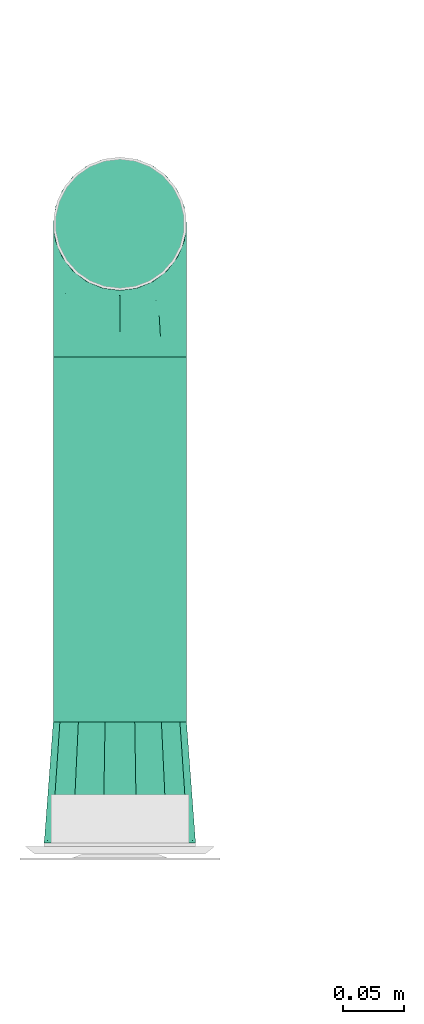
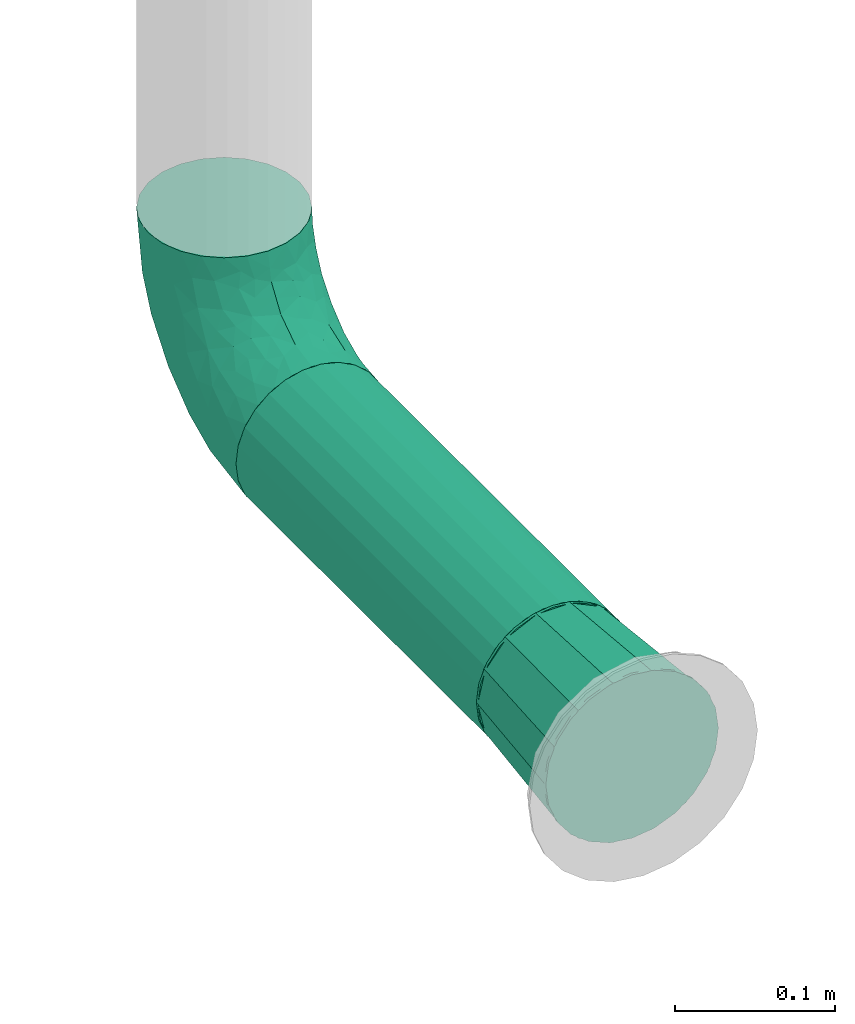
# One storey, part 46 of 123: 2 flow fittings, 1 flow segment.
"""IFC2X3 building model written with IfcOpenShell, lengths in millimetres."""

from ifc_helpers import new_model, entity, si_unit, converted_unit, derived_unit, direction, frame, origin_with_axes, origin_2d_with_axis, place, context, subcontext, project, spatial, hollow_circle, extrude, open_shell, surface_model, source, transform, mapped, material, layer, layer_set, layer_usage, type_object, element, save


model = new_model("IFC2X3")

# Units and contexts
model_context = context("Model", 3, precision=1e-05, world=origin_with_axes(), true_north=direction((0.0, 1.0)))
body_context = subcontext(model_context, "Body", "Model", "MODEL_VIEW")
ifc_project = project(units=[si_unit("AREAUNIT", "SQUARE_METRE"), si_unit("VOLUMEUNIT", "CUBIC_METRE", prefix="DECI"), si_unit("TIMEUNIT", "SECOND"), si_unit("THERMODYNAMICTEMPERATUREUNIT", "DEGREE_CELSIUS"), si_unit("PRESSUREUNIT", "PASCAL"), si_unit("MASSUNIT", "GRAM", prefix="KILO"), si_unit("LENGTHUNIT", "METRE", prefix="MILLI"), si_unit("POWERUNIT", "WATT"), si_unit("ELECTRICCURRENTUNIT", "AMPERE"), si_unit("ELECTRICVOLTAGEUNIT", "VOLT"), derived_unit("VOLUMETRICFLOWRATEUNIT", [(si_unit("VOLUMEUNIT", "CUBIC_METRE", prefix="DECI"), 1), (si_unit("TIMEUNIT", "SECOND"), -1)]), derived_unit("LINEARVELOCITYUNIT", [(si_unit("LENGTHUNIT", "METRE"), 1), (si_unit("TIMEUNIT", "SECOND"), -1)]), derived_unit("MASSDENSITYUNIT", [(si_unit("MASSUNIT", "GRAM", prefix="KILO"), 1), (si_unit("VOLUMEUNIT", "CUBIC_METRE"), -1)]), converted_unit("PLANEANGLEUNIT", "DEGREE", entity("IfcRatioMeasure", 0.01745), si_unit("PLANEANGLEUNIT", "RADIAN"), dimensions=[0, 0, 0, 0, 0, 0, 0])], contexts=[model_context])

# Site, building, storey
site_placement = place(None, origin_with_axes())
site = spatial("IfcSite", under=ifc_project, at=site_placement, CompositionType="ELEMENT")
building_placement = place(site_placement, origin_with_axes())
building = spatial("IfcBuilding", under=site, at=building_placement, Name="mc-building", CompositionType="ELEMENT")
storey_placement = place(building_placement, origin_with_axes())
storey = spatial("IfcBuildingStorey", under=building, at=storey_placement, Name="1. Korrus", CompositionType="ELEMENT", Elevation=0.0)

# Flow fitting
duct_fitting_type_1 = type_object("IfcDuctFittingType", PredefinedType="TRANSITION")
shared_shape_1 = source(origin_with_axes(), body_context, "Body", "SurfaceModel", [
    surface_model("IfcShellBasedSurfaceModel", [(0.0, 16.17619, 60.37037), (0.0, -44.19417, 44.19417), (0.0, 0.0, 62.5), (0.0, 44.19417, 44.19417), (0.0, 31.25, 54.12659), (0.0, 54.12659, 31.25), (0.0, 60.37037, 16.17619), (0.0, -44.19417, -44.19417), (0.0, -16.17619, 60.37037), (0.0, -31.25, 54.12659), (0.0, -60.37037, 16.17619), (0.0, -54.12659, 31.25), (0.0, -62.5, 0.0), (0.0, 62.5, 0.0), (0.0, 60.37037, -16.17619), (0.0, 16.17619, -60.37037), (0.0, 54.12659, -31.25), (0.0, 44.19417, -44.19417), (0.0, 31.25, -54.12659), (0.0, -60.37037, -16.17619), (0.0, -54.12659, -31.25), (0.0, -31.25, -54.12659), (0.0, 0.0, -62.5), (0.0, -16.17619, -60.37037), (100.0, -55.0, 0.0), (100.0, -34.29194, 43.00073), (100.0, -49.55329, 23.86361), (100.0, 34.29194, -43.00073), (100.0, 49.55329, -23.86361), (100.0, 12.23865, -53.62104), (100.0, -34.29194, -43.00073), (100.0, -12.23865, -53.62104), (100.0, 27.5, -47.63139), (100.0, 0.0, -55.0), (100.0, 14.23505, -53.12592), (100.0, 38.89087, -38.89087), (100.0, -27.5, -47.63139), (100.0, 47.63139, -27.5), (100.0, 53.12592, -14.23505), (100.0, 55.0, 0.0), (100.0, -14.23505, -53.12592), (100.0, -47.63139, -27.5), (100.0, -38.89087, -38.89087), (100.0, -53.12592, -14.23505), (100.0, 53.12592, 14.23505), (100.0, 47.63139, 27.5), (100.0, 27.5, 47.63139), (100.0, 38.89087, 38.89087), (100.0, 14.23505, 53.12592), (100.0, 0.0, 55.0), (100.0, -47.63139, 27.5), (100.0, -53.12592, 14.23505), (100.0, -27.5, 47.63139), (100.0, -38.89087, 38.89087), (100.0, -14.23505, 53.12592), (98.0, 0.0, 55.0), (98.0, 14.23505, 53.12592), (98.0, 27.5, 47.63139), (98.0, 38.89087, 38.89087), (98.0, 47.63139, 27.5), (98.0, -47.63139, 27.5), (98.0, 53.12592, -14.23505), (98.0, -27.5, 47.63139), (98.0, -14.23505, 53.12592), (98.0, -38.89087, 38.89087), (98.0, -55.0, 0.0), (98.0, -53.12592, 14.23505), (98.0, 53.12592, 14.23505), (98.0, 47.63139, -27.5), (98.0, -27.5, -47.63139), (98.0, 0.0, -55.0), (98.0, 38.89087, -38.89087), (98.0, 27.5, -47.63139), (98.0, 14.23505, -53.12592), (98.0, -47.63139, -27.5), (98.0, -38.89087, -38.89087), (98.0, -53.12592, -14.23505), (98.0, -14.23505, -53.12592), (98.0, 55.0, 0.0), (100.0, 12.23865, 53.62104), (100.0, -12.23865, 53.62104), (100.0, 49.55329, 23.86361), (100.0, 34.29194, 43.00073), (100.0, -49.55329, -23.86361), (0.0, -56.31055, -27.11773), (0.0, 13.90756, 60.93299), (0.0, 38.96811, 48.86447), (0.0, -13.90756, 60.93299), (0.0, -56.31055, 27.11773), (0.0, -38.96811, 48.86447), (0.0, 56.31055, 27.11773), (0.0, -38.96811, -48.86447), (0.0, 56.31055, -27.11773), (0.0, 38.96811, -48.86447), (0.0, -13.90756, -60.93299), (0.0, 13.90756, -60.93299), (0.0, 59.28804, -14.07253), (100.0, 52.27664, -11.9318), (0.0, 47.63933, -37.9911), (100.0, 41.92261, -33.43217), (0.0, 26.43783, -54.89873), (100.0, 0.0, -53.62104), (0.0, 0.0, -60.93299), (0.0, -26.43783, -54.89873), (100.0, -23.2653, -48.31088), (100.0, 23.2653, -48.31088), (0.0, -59.28804, -14.07253), (100.0, -52.27664, -11.9318), (0.0, -47.63933, -37.9911), (100.0, -41.92261, -33.43217), (0.0, -59.28804, 14.07253), (100.0, -52.27664, 11.9318), (0.0, -47.63933, 37.9911), (100.0, -41.92261, 33.43217), (0.0, -26.43783, 54.89873), (100.0, 0.0, 53.62104), (0.0, 0.0, 60.93299), (0.0, 26.43783, 54.89873), (100.0, 23.2653, 48.31088), (100.0, -23.2653, 48.31088), (0.0, 59.28804, 14.07253), (100.0, 52.27664, 11.9318), (0.0, 47.63933, 37.9911), (100.0, 41.92261, 33.43217), (2.0, 16.17619, -60.37037), (2.0, 31.25, -54.12659), (2.0, 44.19417, -44.19417), (2.0, 54.12659, -31.25), (2.0, 60.37037, -16.17619), (2.0, -44.19417, -44.19417), (2.0, 62.5, 0.0), (2.0, 0.0, -62.5), (2.0, -31.25, -54.12659), (2.0, -16.17619, -60.37037), (2.0, -60.37037, -16.17619), (2.0, -54.12659, -31.25), (2.0, -62.5, 0.0), (2.0, -44.19417, 44.19417), (2.0, 0.0, 62.5), (2.0, 60.37037, 16.17619), (2.0, 54.12659, 31.25), (2.0, 16.17619, 60.37037), (2.0, 44.19417, 44.19417), (2.0, 31.25, 54.12659), (2.0, -60.37037, 16.17619), (2.0, -54.12659, 31.25), (2.0, -16.17619, 60.37037), (2.0, -31.25, 54.12659)], [open_shell([[[0, 1, 2]], [[3, 0, 4]], [[5, 6, 0]], [[5, 0, 3]], [[0, 7, 1]], [[8, 1, 9]], [[8, 2, 1]], [[1, 10, 11]], [[10, 1, 12]], [[1, 7, 12]], [[0, 6, 13]], [[14, 7, 13]], [[15, 14, 16]], [[17, 18, 15]], [[17, 15, 16]], [[7, 14, 15]], [[19, 7, 20]], [[12, 7, 19]], [[21, 22, 23]], [[22, 21, 7]], [[15, 22, 7]], [[7, 0, 13]], [[24, 25, 26]], [[27, 28, 29]], [[29, 28, 24]], [[30, 31, 29]], [[32, 33, 34]], [[35, 36, 32]], [[36, 37, 38]], [[35, 37, 36]], [[39, 36, 38]], [[33, 36, 40]], [[33, 32, 36]], [[36, 41, 42]], [[36, 39, 41]], [[24, 43, 41]], [[41, 39, 44]], [[45, 24, 44]], [[46, 45, 47]], [[46, 48, 49]], [[45, 46, 24]], [[49, 50, 46]], [[24, 50, 51]], [[24, 46, 50]], [[49, 52, 53]], [[53, 50, 49]], [[52, 49, 54]], [[44, 24, 41]], [[55, 56, 57]], [[55, 57, 58]], [[55, 59, 60]], [[59, 55, 58]], [[61, 60, 59]], [[55, 62, 63]], [[55, 64, 62]], [[60, 65, 66]], [[64, 55, 60]], [[60, 61, 65]], [[61, 59, 67]], [[61, 68, 65]], [[68, 69, 65]], [[70, 71, 72]], [[68, 71, 70]], [[72, 73, 70]], [[74, 69, 75]], [[76, 65, 74]], [[69, 70, 77]], [[74, 65, 69]], [[70, 69, 68]], [[78, 61, 67]], [[76, 43, 65]], [[74, 41, 76]], [[36, 75, 69]], [[74, 75, 42]], [[40, 69, 77]], [[76, 41, 43]], [[43, 24, 65]], [[40, 36, 69]], [[42, 75, 36]], [[42, 41, 74]], [[33, 40, 77]], [[77, 70, 33]], [[73, 34, 70]], [[72, 32, 73]], [[37, 71, 68]], [[72, 71, 35]], [[38, 68, 61]], [[72, 35, 32]], [[32, 34, 73]], [[39, 38, 61]], [[37, 68, 38]], [[37, 35, 71]], [[78, 39, 61]], [[70, 34, 33]], [[67, 44, 78]], [[59, 45, 67]], [[46, 58, 57]], [[59, 58, 47]], [[48, 57, 56]], [[67, 45, 44]], [[44, 39, 78]], [[48, 46, 57]], [[47, 58, 46]], [[47, 45, 59]], [[49, 48, 56]], [[56, 55, 49]], [[63, 54, 55]], [[62, 52, 63]], [[50, 64, 60]], [[62, 64, 53]], [[51, 60, 66]], [[62, 53, 52]], [[52, 54, 63]], [[24, 51, 66]], [[50, 60, 51]], [[50, 53, 64]], [[65, 24, 66]], [[55, 54, 49]], [[24, 79, 80]], [[25, 24, 80]], [[81, 82, 24]], [[24, 39, 81]], [[79, 24, 82]], [[24, 83, 30]], [[24, 30, 29]], [[24, 28, 39]], [[84, 85, 86]], [[84, 87, 85]], [[88, 89, 84]], [[84, 12, 88]], [[87, 84, 89]], [[13, 86, 90]], [[91, 13, 92]], [[91, 92, 93]], [[84, 13, 91]], [[94, 91, 93]], [[95, 94, 93]], [[13, 84, 86]], [[28, 96, 97]], [[98, 28, 99]], [[27, 100, 93]], [[101, 94, 102]], [[103, 31, 104]], [[28, 98, 92]], [[102, 95, 29]], [[13, 97, 96]], [[105, 29, 95]], [[99, 93, 98]], [[105, 95, 100]], [[99, 27, 93]], [[94, 101, 31]], [[31, 103, 94]], [[106, 83, 107]], [[83, 84, 108]], [[30, 109, 91]], [[12, 106, 107]], [[12, 107, 24]], [[97, 13, 39]], [[104, 91, 103]], [[28, 92, 96]], [[83, 106, 84]], [[108, 109, 83]], [[100, 27, 105]], [[91, 109, 108]], [[102, 29, 101]], [[104, 30, 91]], [[26, 110, 111]], [[112, 26, 113]], [[25, 114, 89]], [[115, 85, 116]], [[117, 79, 118]], [[26, 112, 88]], [[116, 87, 80]], [[12, 111, 110]], [[119, 80, 87]], [[113, 89, 112]], [[119, 87, 114]], [[113, 25, 89]], [[85, 115, 79]], [[79, 117, 85]], [[120, 81, 121]], [[81, 90, 122]], [[82, 123, 86]], [[13, 120, 121]], [[13, 121, 39]], [[111, 12, 24]], [[118, 86, 117]], [[26, 88, 110]], [[81, 120, 90]], [[122, 123, 81]], [[114, 25, 119]], [[86, 123, 122]], [[116, 80, 115]], [[118, 82, 86]], [[124, 125, 126]], [[124, 126, 127]], [[124, 128, 129]], [[128, 124, 127]], [[129, 128, 130]], [[131, 132, 133]], [[132, 131, 129]], [[129, 134, 135]], [[129, 131, 124]], [[129, 136, 134]], [[129, 130, 137]], [[138, 139, 140]], [[141, 140, 142]], [[141, 138, 140]], [[141, 142, 143]], [[139, 138, 137]], [[144, 137, 145]], [[137, 144, 136]], [[137, 146, 147]], [[136, 129, 137]], [[138, 146, 137]], [[137, 130, 139]], [[19, 134, 12]], [[20, 135, 19]], [[132, 7, 21]], [[20, 7, 129]], [[133, 21, 23]], [[19, 135, 134]], [[134, 136, 12]], [[133, 132, 21]], [[129, 7, 132]], [[129, 135, 20]], [[131, 133, 23]], [[23, 22, 131]], [[15, 124, 22]], [[18, 125, 15]], [[127, 17, 16]], [[18, 17, 126]], [[128, 16, 14]], [[18, 126, 125]], [[125, 124, 15]], [[130, 128, 14]], [[127, 16, 128]], [[127, 126, 17]], [[13, 130, 14]], [[22, 124, 131]], [[6, 139, 13]], [[5, 140, 6]], [[143, 3, 4]], [[5, 3, 142]], [[141, 4, 0]], [[6, 140, 139]], [[139, 130, 13]], [[141, 143, 4]], [[142, 3, 143]], [[142, 140, 5]], [[138, 141, 0]], [[0, 2, 138]], [[8, 146, 2]], [[9, 147, 8]], [[145, 1, 11]], [[9, 1, 137]], [[144, 11, 10]], [[9, 137, 147]], [[147, 146, 8]], [[136, 144, 10]], [[145, 11, 144]], [[145, 137, 1]], [[12, 136, 10]], [[2, 146, 138]]])]),
])
flow_fitting_1_placement = place(storey_placement, frame((2232.32005, 7578.1, 2480.0), z_axis=(0.0, 0.0, 1.0), x_axis=(0.0, 1.0, 0.0)))
element("IfcFlowFitting", 1, at=flow_fitting_1_placement, inside=storey, type_object=duct_fitting_type_1, context=body_context, shape_type="MappedRepresentation", body=[
    mapped(shared_shape_1, transform((0.0, 0.0, 0.0), scale=1.0)),
])

# Flow segment
ifc_material = material(Name="FZ1")
ifc_layer = layer(ifc_material, 0.0)
ifc_layer_set = layer_set([ifc_layer], Name="FZ1")
ifc_layer_usage = layer_usage(ifc_layer_set, "AXIS1", "POSITIVE", 0.0)
duct_segment_type = type_object("IfcDuctSegmentType", PredefinedType="RIGIDSEGMENT")
shared_shape_2 = source(origin_with_axes(), body_context, "Body", "SweptSolid", [
    extrude(hollow_circle(Radius=55.0, WallThickness=2.0, at=origin_2d_with_axis()), frame((0.0, 0.0, 0.0), z_axis=(1.0, 0.0, 0.0), x_axis=(0.0, 1.0, 0.0)), (0.0, 0.0, 1.0), 301.3),
])
flow_segment_placement = place(storey_placement, frame((2232.32005, 7678.1, 2480.0), z_axis=(0.0, 0.0, 1.0), x_axis=(0.0, 1.0, 0.0)))
element("IfcFlowSegment", 2, at=flow_segment_placement, inside=storey, type_object=duct_segment_type, material=ifc_layer_usage, context=body_context, shape_type="MappedRepresentation", body=[
    mapped(shared_shape_2, transform((0.0, 0.0, 0.0), scale=1.0)),
])

# Flow fitting
duct_fitting_type_2 = type_object("IfcDuctFittingType", Name="BU", PredefinedType="BEND")
shared_shape_3 = source(origin_with_axes(), body_context, "Body", "SurfaceModel", [
    surface_model("IfcShellBasedSurfaceModel", [(-110.0, 0.0, -55.0), (-110.0, -14.23505, -53.12592), (-110.0, 14.23505, -53.12592), (-110.0, 53.12592, 14.23505), (-110.0, 27.5, -47.63139), (-110.0, 38.89087, -38.89087), (-110.0, -55.0, 0.0), (-110.0, -53.12592, 14.23505), (-110.0, -38.89087, -38.89087), (-110.0, -27.5, -47.63139), (-110.0, -53.12592, -14.23505), (-110.0, -47.63139, -27.5), (-110.0, -14.23505, 53.12592), (-110.0, 14.23505, 53.12592), (-110.0, 27.5, 47.63139), (-110.0, -47.63139, 27.5), (-110.0, -38.89087, 38.89087), (-110.0, -27.5, 47.63139), (-110.0, 0.0, 55.0), (-110.0, 55.0, 0.0), (-110.0, 53.12592, -14.23505), (-110.0, 47.63139, -27.5), (-110.0, 47.63139, 27.5), (-110.0, 38.89087, 38.89087), (-14.23505, 110.0, -53.12592), (-55.0, 110.0, 0.0), (0.0, 110.0, -55.0), (-27.5, 110.0, -47.63139), (-38.89087, 110.0, -38.89087), (-47.63139, 110.0, -27.5), (38.89087, 110.0, -38.89087), (53.12592, 110.0, 14.23505), (27.5, 110.0, -47.63139), (14.23505, 110.0, -53.12592), (47.63139, 110.0, -27.5), (53.12592, 110.0, -14.23505), (55.0, 110.0, 0.0), (-53.12592, 110.0, -14.23505), (-53.12592, 110.0, 14.23505), (-47.63139, 110.0, 27.5), (-38.89087, 110.0, 38.89087), (-27.5, 110.0, 47.63139), (0.0, 110.0, 55.0), (-14.23505, 110.0, 53.12592), (38.89087, 110.0, 38.89087), (47.63139, 110.0, 27.5), (27.5, 110.0, 47.63139), (14.23505, 110.0, 53.12592), (-64.21732, 48.68956, 43.63444), (-76.6405, 38.18013, 45.55988), (-60.44912, 32.56953, 51.94617), (-76.00813, 5.38378, 55.0), (-90.15553, 11.94394, 54.09138), (-78.5998, 26.77405, 50.81338), (-70.18771, 18.55163, 54.03432), (-75.55424, 54.2118, 32.41257), (-93.27622, 45.77614, 33.48188), (-96.12334, 22.13664, 50.81337), (-21.00813, 45.34362, 55.0), (-18.36258, 70.48427, 54.04484), (-32.04182, 59.64019, 52.24446), (-63.88653, 74.77858, 17.99134), (-74.66383, 63.08407, 19.92123), (-63.60674, 66.07878, 29.97482), (-99.597, 52.72185, 18.52927), (-93.11138, 56.59448, 10.50359), (-98.21577, 57.34403, 0.0), (-53.42855, 92.60092, 21.04759), (-88.54852, 54.8376, 21.04759), (-11.86161, 90.23965, 54.10313), (-5.38378, 76.00813, 55.0), (-57.34403, 98.21577, 0.0), (-56.64619, 93.12774, 10.22088), (-45.34362, 21.00813, 55.0), (-44.60838, 44.60838, 52.13415), (-92.68484, 35.46673, 43.63443), (-22.25266, 95.40765, 50.81337), (-35.97783, 90.61597, 43.63443), (-43.70931, 69.58671, 44.47149), (-27.23711, 77.39884, 50.81337), (-57.2828, 79.3123, 24.9774), (-58.67786, 84.31125, 16.04456), (-82.93277, 60.36161, 12.91784), (-49.88337, 54.51816, 47.224), (-74.57753, 66.83759, 9.55742), (-45.35812, 94.97281, 33.48188), (-59.18663, 88.95241, 0.0), (-51.517, 78.6292, 33.48188), (-65.14788, 80.03077, 0.0), (-56.45322, 62.06476, 39.63545), (-88.95241, 59.18663, 0.0), (-71.10913, 71.10913, 0.0), (-80.03077, 65.14788, 0.0), (-94.9309, 45.36788, -33.48188), (-93.11358, 56.60141, -10.46614), (-99.64997, 52.79499, -18.30015), (-90.20425, 36.08686, -43.63443), (-79.99933, 46.56772, -37.92748), (-76.00813, 5.38378, -55.0), (-72.75364, 19.68651, -53.60527), (-45.34362, 21.00813, -55.0), (-21.91957, 65.12078, -53.85897), (-5.38378, 76.00813, -55.0), (-21.00813, 45.34362, -55.0), (-35.41876, 92.89265, -43.63443), (-91.10309, 11.02766, -54.21832), (-45.77614, 93.27622, -33.48188), (-90.50474, 23.21022, -50.81337), (-70.92854, 33.31794, -49.51754), (-78.52933, 63.35627, -11.73997), (-24.91508, 84.05606, -50.81337), (-88.78941, 54.74452, -21.04759), (-69.59921, 57.34866, -33.48187), (-73.36422, 62.46673, -22.94182), (-63.49062, 67.59111, -28.46929), (-56.59448, 93.11138, -10.50359), (-54.8376, 88.54852, -21.04759), (-54.10679, 75.85581, -32.31867), (-57.75956, 31.09612, -52.80882), (-52.72185, 99.597, -18.52927), (-12.62913, 89.46304, -53.99097), (-34.46825, 66.46123, -50.04329), (-43.9837, 43.9837, -52.42279), (-65.78527, 72.58348, -17.68796), (-70.34468, 43.65295, -44.21951), (-57.47001, 51.99467, -44.91465), (-60.72547, 82.29174, -12.88567), (-42.34915, 74.24548, -43.63444), (-57.25194, 63.5016, -38.08211), (-80.95344, 53.56991, -29.32027), (-52.32891, 4.55257, -54.0482), (32.52942, 47.13398, -30.48571), (14.88266, 20.92917, -33.7947), (14.95561, 36.05775, -42.26543), (30.24048, 70.09027, -41.7461), (19.3559, 65.35825, -48.00507), (-70.35075, -46.44478, -19.5952), (-47.13398, -32.52942, -30.48571), (-28.49299, -30.5778, -16.4009), (-4.55257, 52.32891, -54.0482), (-22.4954, 22.4954, -53.25347), (-75.47368, -11.22546, -52.60718), (-81.32209, -51.5606, -9.98467), (-80.81763, -41.84862, -32.14655), (-70.09027, -30.24048, -41.7461), (-36.05774, -14.95561, -42.26543), (-9.15831, -10.852, -27.8997), (-65.35825, -19.3559, -48.00507), (11.22546, 75.47368, -52.60718), (3.94376, 43.9333, -50.53315), (-13.39742, 13.39743, -48.13058), (-43.9333, -3.94376, -50.53315), (49.37776, 67.29486, 0.0), (41.8609, 47.82256, -9.92641), (50.20582, 74.51695, -9.9731), (18.93131, 11.7156, -17.56239), (-27.5, -32.89419, 0.0), (-1.23348, -12.25375, -12.18106), (41.84862, 80.81763, -32.14655), (35.70604, 41.31408, -20.38235), (46.44478, 70.35075, -19.5952), (32.89419, 27.5, 0.0), (6.67262, -6.67262, 0.0), (-67.29486, -49.37776, 0.0), (-50.36265, -42.95545, -9.51562), (-5.47251, 5.47251, -39.92906), (-70.35075, -46.44478, 19.5952), (-74.51695, -50.20582, 9.9731), (-41.31407, -35.70604, 20.38235), (-47.13398, -32.52942, 30.48571), (-80.81763, -41.84862, 32.14655), (-4.55257, 52.32891, 54.0482), (11.22546, 75.47368, 52.60718), (-43.9333, -3.94376, 50.53315), (-65.35825, -19.3559, 48.00507), (-36.05774, -14.95561, 42.26543), (-70.09027, -30.24048, 41.7461), (-11.7156, -18.93131, 17.56239), (30.5778, 28.49299, 16.4009), (12.25375, 1.23348, 12.18106), (51.5606, 81.32209, 9.98467), (42.95545, 50.36265, 9.51562), (-75.47368, -11.22546, 52.60718), (-52.32891, 4.55257, 54.0482), (3.94376, 43.9333, 50.53315), (-22.4954, 22.4954, 53.25347), (-13.39742, 13.39743, 48.13058), (10.852, 9.15831, 27.8997), (-20.92916, -14.88266, 33.79469), (-47.82256, -41.8609, 9.92641), (32.52942, 47.13398, 30.48571), (46.44478, 70.35075, 19.5952), (41.84862, 80.81763, 32.14655), (30.24048, 70.09027, 41.7461), (19.3559, 65.35825, 48.00507), (14.95561, 36.05775, 42.26543), (-5.47251, 5.47251, 39.92906)], [open_shell([[[0, 1, 2]], [[2, 3, 4]], [[4, 3, 5]], [[2, 6, 7]], [[8, 6, 9]], [[1, 9, 6]], [[10, 6, 11]], [[8, 11, 6]], [[6, 2, 1]], [[12, 13, 14]], [[15, 2, 7]], [[16, 17, 2]], [[2, 17, 12]], [[12, 18, 13]], [[19, 20, 3]], [[5, 3, 21]], [[20, 21, 3]], [[22, 3, 2]], [[23, 22, 2]], [[12, 14, 2]], [[2, 14, 23]], [[15, 16, 2]], [[24, 25, 26]], [[27, 25, 24]], [[25, 28, 29]], [[28, 25, 27]], [[30, 26, 31]], [[26, 30, 32]], [[32, 33, 26]], [[34, 31, 35]], [[31, 34, 30]], [[35, 31, 36]], [[29, 37, 25]], [[38, 39, 26]], [[39, 40, 26]], [[41, 42, 40]], [[42, 26, 40]], [[42, 41, 43]], [[26, 44, 45]], [[31, 26, 45]], [[26, 46, 44]], [[47, 46, 26]], [[42, 47, 26]], [[25, 38, 26]], [[48, 49, 50]], [[18, 51, 52]], [[53, 54, 50]], [[55, 56, 49]], [[56, 22, 23]], [[13, 57, 14]], [[58, 59, 60]], [[61, 62, 63]], [[3, 64, 65]], [[53, 52, 54]], [[3, 65, 66]], [[67, 39, 38]], [[56, 68, 64]], [[65, 64, 68]], [[69, 59, 70]], [[38, 71, 72]], [[73, 58, 74]], [[75, 49, 56]], [[76, 69, 43]], [[53, 57, 52]], [[77, 78, 79]], [[41, 76, 43]], [[43, 69, 42]], [[55, 68, 56]], [[23, 14, 75]], [[76, 77, 79]], [[80, 67, 81]], [[62, 82, 68]], [[60, 78, 83]], [[62, 84, 82]], [[85, 77, 40]], [[81, 67, 72]], [[86, 72, 71]], [[87, 85, 67]], [[61, 81, 88]], [[77, 41, 40]], [[78, 77, 87]], [[23, 75, 56]], [[83, 89, 48]], [[85, 40, 39]], [[62, 68, 55]], [[89, 87, 63]], [[83, 48, 50]], [[57, 75, 14]], [[49, 75, 53]], [[67, 85, 39]], [[87, 77, 85]], [[63, 62, 55]], [[89, 55, 48]], [[80, 63, 87]], [[66, 65, 90]], [[66, 19, 3]], [[84, 91, 92]], [[92, 90, 82]], [[65, 82, 90]], [[61, 84, 62]], [[92, 82, 84]], [[68, 82, 65]], [[3, 22, 64]], [[56, 64, 22]], [[38, 25, 71]], [[81, 72, 86]], [[38, 72, 67]], [[91, 61, 88]], [[80, 81, 61]], [[63, 80, 61]], [[67, 80, 87]], [[77, 76, 41]], [[79, 59, 69]], [[79, 69, 76]], [[42, 69, 70]], [[60, 59, 79]], [[58, 70, 59]], [[78, 60, 79]], [[58, 60, 74]], [[52, 57, 13]], [[75, 57, 53]], [[18, 52, 13]], [[52, 51, 54]], [[51, 73, 54]], [[50, 73, 74]], [[73, 50, 54]], [[50, 74, 83]], [[60, 83, 74]], [[89, 83, 78]], [[87, 89, 78]], [[55, 89, 63]], [[50, 49, 53]], [[55, 49, 48]], [[81, 86, 88]], [[91, 84, 61]], [[5, 21, 93]], [[90, 94, 66]], [[20, 94, 95]], [[96, 93, 97]], [[98, 99, 100]], [[96, 4, 5]], [[101, 102, 103]], [[28, 27, 104]], [[2, 105, 0]], [[104, 106, 28]], [[99, 105, 107]], [[108, 107, 96]], [[90, 109, 94]], [[107, 2, 4]], [[20, 66, 94]], [[27, 24, 110]], [[109, 111, 94]], [[112, 113, 114]], [[37, 115, 71]], [[116, 106, 117]], [[99, 118, 100]], [[116, 115, 119]], [[37, 119, 115]], [[24, 120, 110]], [[121, 110, 101]], [[119, 106, 116]], [[101, 110, 120]], [[122, 103, 100]], [[117, 123, 116]], [[124, 125, 108]], [[115, 116, 126]], [[106, 29, 28]], [[26, 102, 120]], [[127, 104, 110]], [[97, 124, 96]], [[125, 122, 118]], [[128, 127, 125]], [[96, 5, 93]], [[115, 126, 86]], [[117, 106, 127]], [[111, 113, 129]], [[95, 93, 21]], [[97, 129, 112]], [[110, 104, 27]], [[106, 104, 127]], [[96, 107, 4]], [[99, 107, 108]], [[99, 108, 118]], [[105, 99, 98]], [[112, 114, 128]], [[121, 125, 127]], [[20, 19, 66]], [[109, 90, 92]], [[94, 111, 95]], [[91, 123, 109]], [[129, 113, 112]], [[93, 95, 111]], [[21, 20, 95]], [[71, 115, 86]], [[71, 25, 37]], [[123, 91, 88]], [[126, 116, 123]], [[123, 88, 126]], [[86, 126, 88]], [[37, 29, 119]], [[106, 119, 29]], [[129, 93, 111]], [[124, 112, 125]], [[0, 105, 98]], [[107, 105, 2]], [[125, 118, 108]], [[100, 118, 122]], [[93, 129, 97]], [[113, 111, 109]], [[109, 123, 113]], [[114, 123, 117]], [[123, 114, 113]], [[128, 114, 117]], [[127, 128, 117]], [[112, 128, 125]], [[103, 122, 101]], [[110, 121, 127]], [[101, 122, 121]], [[125, 121, 122]], [[26, 120, 24]], [[101, 120, 102]], [[96, 124, 108]], [[92, 91, 109]], [[112, 124, 97]], [[100, 130, 98]], [[131, 132, 133]], [[32, 134, 135]], [[136, 137, 138]], [[139, 140, 103]], [[98, 141, 0]], [[142, 10, 136]], [[143, 144, 137]], [[6, 10, 142]], [[137, 145, 146]], [[144, 147, 145]], [[143, 136, 11]], [[11, 136, 10]], [[8, 143, 11]], [[148, 149, 139]], [[8, 9, 144]], [[9, 1, 147]], [[130, 141, 98]], [[103, 140, 100]], [[148, 135, 149]], [[150, 151, 140]], [[152, 153, 154]], [[130, 140, 151]], [[148, 26, 33]], [[147, 1, 141]], [[155, 146, 132]], [[156, 138, 157]], [[134, 30, 158]], [[150, 140, 149]], [[158, 30, 34]], [[30, 134, 32]], [[153, 159, 160]], [[131, 160, 159]], [[144, 145, 137]], [[36, 152, 154]], [[146, 138, 137]], [[155, 161, 162]], [[158, 160, 131]], [[133, 149, 135]], [[156, 163, 164]], [[163, 142, 164]], [[139, 103, 102]], [[153, 152, 161]], [[34, 35, 160]], [[162, 157, 155]], [[132, 165, 133]], [[157, 146, 155]], [[140, 130, 100]], [[141, 130, 151]], [[141, 151, 147]], [[141, 1, 0]], [[102, 26, 148]], [[140, 139, 149]], [[102, 148, 139]], [[135, 33, 32]], [[151, 150, 145]], [[9, 147, 144]], [[151, 145, 147]], [[145, 165, 146]], [[135, 148, 33]], [[133, 135, 134]], [[131, 133, 134]], [[133, 165, 150]], [[133, 150, 149]], [[145, 150, 165]], [[132, 131, 159]], [[146, 165, 132]], [[160, 158, 34]], [[134, 158, 131]], [[144, 143, 8]], [[136, 143, 137]], [[155, 153, 161]], [[154, 153, 160]], [[153, 155, 159]], [[132, 159, 155]], [[160, 35, 154]], [[36, 154, 35]], [[164, 136, 138]], [[6, 142, 163]], [[136, 164, 142]], [[156, 164, 138]], [[156, 157, 162]], [[146, 157, 138]], [[15, 7, 166]], [[6, 163, 167]], [[168, 169, 166]], [[166, 169, 170]], [[171, 172, 70]], [[173, 174, 175]], [[17, 176, 174]], [[177, 156, 162]], [[176, 16, 170]], [[170, 16, 15]], [[161, 178, 179]], [[152, 180, 181]], [[182, 173, 183]], [[18, 12, 182]], [[184, 185, 186]], [[183, 185, 73]], [[183, 73, 51]], [[177, 187, 188]], [[189, 168, 166]], [[187, 178, 190]], [[16, 176, 17]], [[161, 152, 181]], [[45, 191, 31]], [[45, 44, 192]], [[192, 191, 45]], [[180, 36, 31]], [[193, 194, 195]], [[46, 47, 194]], [[193, 195, 190]], [[193, 44, 46]], [[172, 42, 70]], [[185, 58, 73]], [[189, 163, 156]], [[163, 189, 167]], [[70, 58, 171]], [[184, 171, 185]], [[169, 188, 175]], [[180, 31, 191]], [[192, 193, 190]], [[191, 190, 178]], [[182, 174, 173]], [[194, 47, 172]], [[190, 195, 187]], [[186, 185, 173]], [[162, 179, 177]], [[188, 196, 175]], [[179, 187, 177]], [[185, 171, 58]], [[172, 171, 184]], [[172, 184, 194]], [[172, 47, 42]], [[51, 18, 182]], [[185, 183, 173]], [[51, 182, 183]], [[174, 12, 17]], [[184, 186, 195]], [[46, 194, 193]], [[184, 195, 194]], [[195, 196, 187]], [[174, 182, 12]], [[175, 174, 176]], [[169, 175, 176]], [[175, 196, 186]], [[175, 186, 173]], [[195, 186, 196]], [[188, 169, 168]], [[187, 196, 188]], [[166, 170, 15]], [[176, 170, 169]], [[193, 192, 44]], [[191, 192, 190]], [[177, 189, 156]], [[167, 189, 166]], [[189, 177, 168]], [[188, 168, 177]], [[166, 7, 167]], [[6, 167, 7]], [[181, 191, 178]], [[36, 180, 152]], [[191, 181, 180]], [[161, 181, 178]], [[161, 179, 162]], [[187, 179, 178]]])]),
])
flow_fitting_2_placement = place(storey_placement, frame((2232.32005, 8089.38441, 2480.0), z_axis=(1.0, 0.0, 0.0), x_axis=(0.0, 1.0, 0.0)))
element("IfcFlowFitting", 3, at=flow_fitting_2_placement, inside=storey, type_object=duct_fitting_type_2, Name="BU", context=body_context, shape_type="MappedRepresentation", body=[
    mapped(shared_shape_3, transform((0.0, 0.0, 0.0), scale=1.0)),
])

save(model, "model.ifc")
